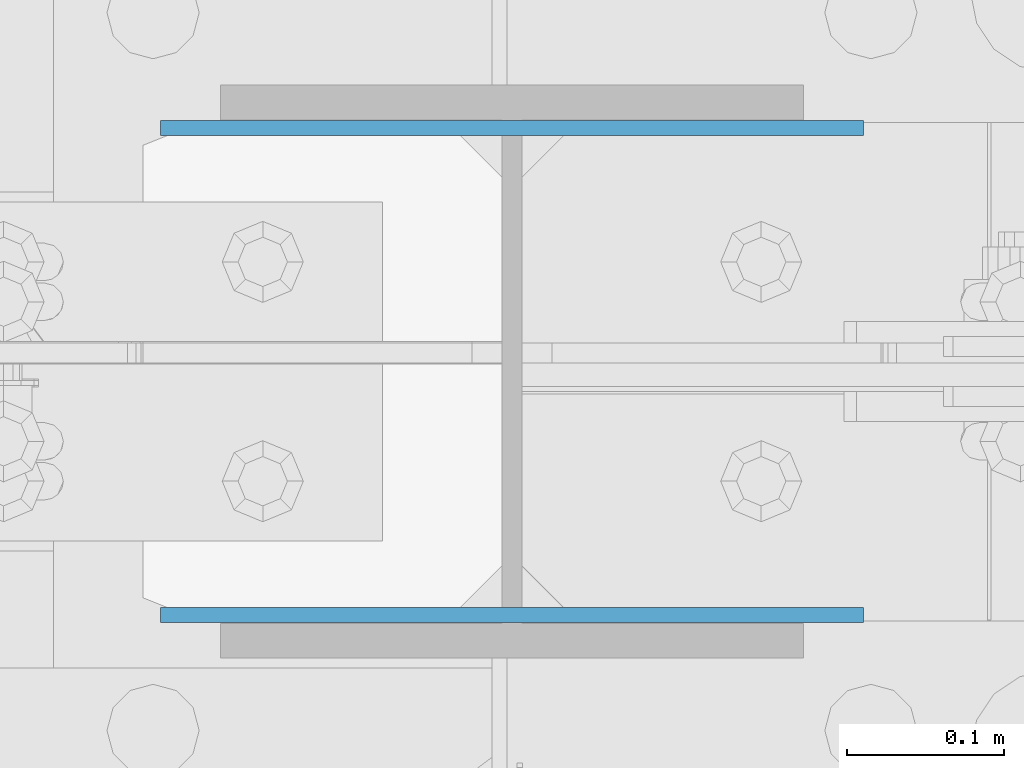
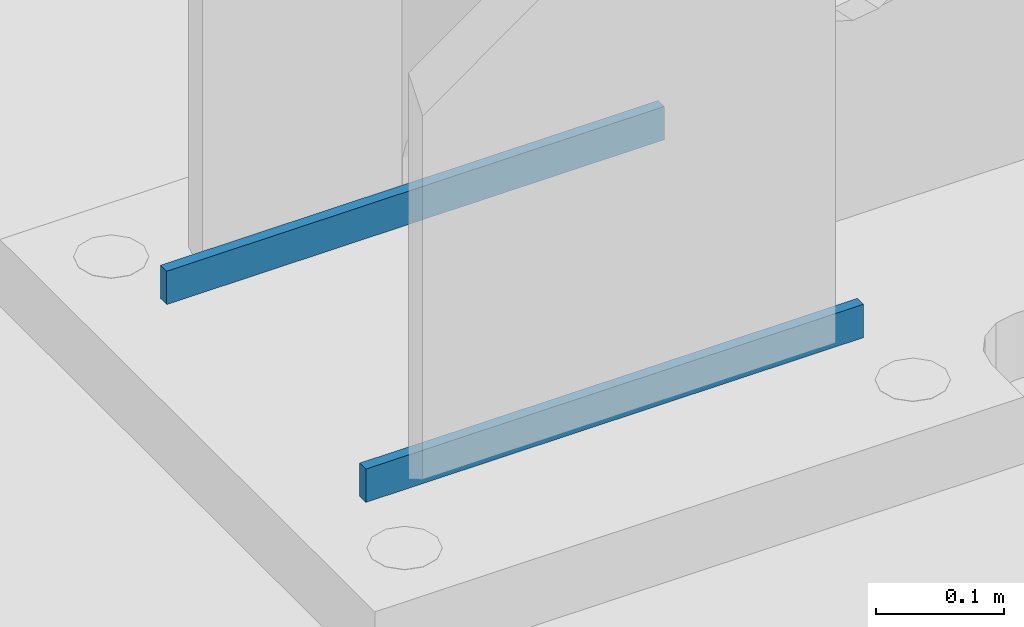
# One storey, part 433 of 1179: 2 columns, 1 element without a shape of its own.
"""IFC2X3 building model written with IfcOpenShell, lengths in millimetres."""

from ifc_helpers import new_model, si_unit, frame, origin_with_axes, place, context, subcontext, project, spatial, faceted_brep, material, type_object, element, aggregate, save


model = new_model("IFC2X3")

# Units and contexts
model_context = context("Model", 3, precision=1e-05, world=origin_with_axes())
body_context = subcontext(model_context, "Body", "Model", "MODEL_VIEW")
ifc_project = project(units=[si_unit("LENGTHUNIT", "METRE", prefix="MILLI"), si_unit("AREAUNIT", "SQUARE_METRE"), si_unit("VOLUMEUNIT", "CUBIC_METRE"), si_unit("MASSUNIT", "GRAM", prefix="KILO"), si_unit("TIMEUNIT", "SECOND"), si_unit("PLANEANGLEUNIT", "RADIAN"), si_unit("SOLIDANGLEUNIT", "STERADIAN"), si_unit("THERMODYNAMICTEMPERATUREUNIT", "DEGREE_CELSIUS"), si_unit("LUMINOUSINTENSITYUNIT", "LUMEN")], contexts=[model_context])

# Site, building, storey
site_placement = place(None, origin_with_axes())
site = spatial("IfcSite", under=ifc_project, at=site_placement, CompositionType="ELEMENT")
building_placement = place(site_placement, origin_with_axes())
building = spatial("IfcBuilding", under=site, at=building_placement, Name="Undefined", CompositionType="ELEMENT")
storey_placement = place(building_placement, origin_with_axes())
storey = spatial("IfcBuildingStorey", under=building, at=storey_placement, Name="Undefined", CompositionType="ELEMENT", Elevation=0.0)

# Assembly, columns
assembly_placement = place(storey_placement, origin_with_axes())
assembly = element("IfcElementAssembly", 1, at=assembly_placement, inside=storey, Name="COLUMN", AssemblyPlace="NOTDEFINED", PredefinedType="RIGID_FRAME")
ifc_material = material(Name="STEEL/A572-GR.50")
column_type = type_object("IfcColumnType", PredefinedType="NOTDEFINED")
column_1_placement = place(assembly_placement, frame((8280.4, 26895.822, -215.9), z_axis=(-1.0, 0.0, 0.0), x_axis=(0.0, 0.0, 1.0)))
column_1 = element("IfcColumn", 2, at=column_1_placement, type_object=column_type, material=ifc_material, Name="PLATE", context=body_context, shape_type="Brep", body=[
    faceted_brep([(0.0, 4.76250000000073, -223.837500000001), (0.0, 4.76250000000073, 223.8375), (31.75, 4.76250000000073, 223.8375), (31.75, 4.76250000000073, -223.837500000001), (0.0, -4.76250000000073, 223.8375), (31.75, -4.76250000000073, 223.8375), (0.0, -4.76250000000073, -223.837500000001), (31.75, -4.76250000000073, -223.837500000001)], [[[0, 1, 2, 3]], [[1, 4, 5, 2]], [[4, 6, 7, 5]], [[6, 0, 3, 7]], [[5, 7, 3, 2]], [[6, 4, 1, 0]]]),
])
column_2_placement = place(assembly_placement, frame((8280.4, 27206.178, -215.9), z_axis=(-1.0, 0.0, 0.0), x_axis=(0.0, 0.0, 1.0)))
column_2 = element("IfcColumn", 3, at=column_2_placement, type_object=column_type, material=ifc_material, Name="PLATE", context=body_context, shape_type="Brep", body=[
    faceted_brep([(0.0, 4.76250000000073, -223.837500000001), (0.0, 4.76250000000073, 223.8375), (31.75, 4.76250000000073, 223.8375), (31.75, 4.76250000000073, -223.837500000001), (0.0, -4.76250000000073, 223.8375), (31.75, -4.76250000000073, 223.8375), (0.0, -4.76250000000073, -223.837500000001), (31.75, -4.76250000000073, -223.837500000001)], [[[0, 1, 2, 3]], [[1, 4, 5, 2]], [[4, 6, 7, 5]], [[6, 0, 3, 7]], [[5, 7, 3, 2]], [[6, 4, 1, 0]]]),
])
aggregate(assembly, [column_1, column_2])

save(model, "model.ifc")
